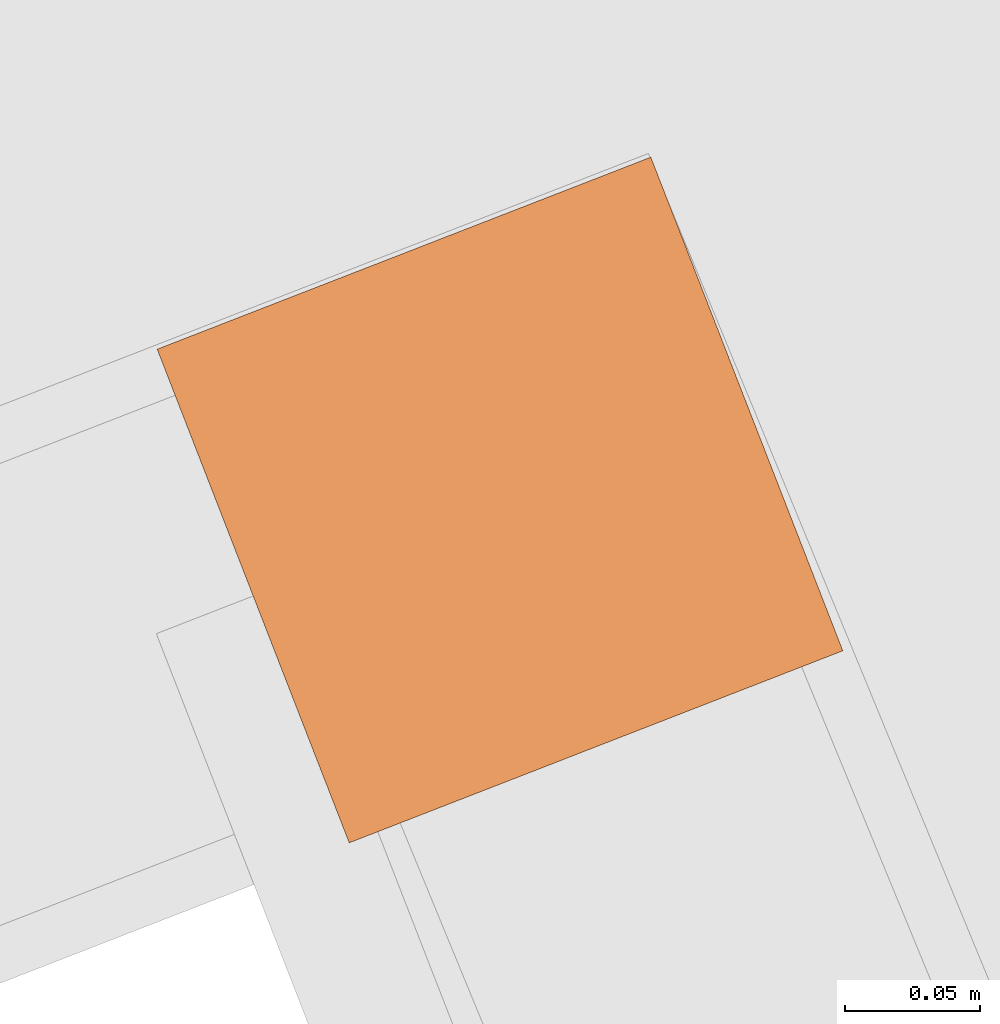
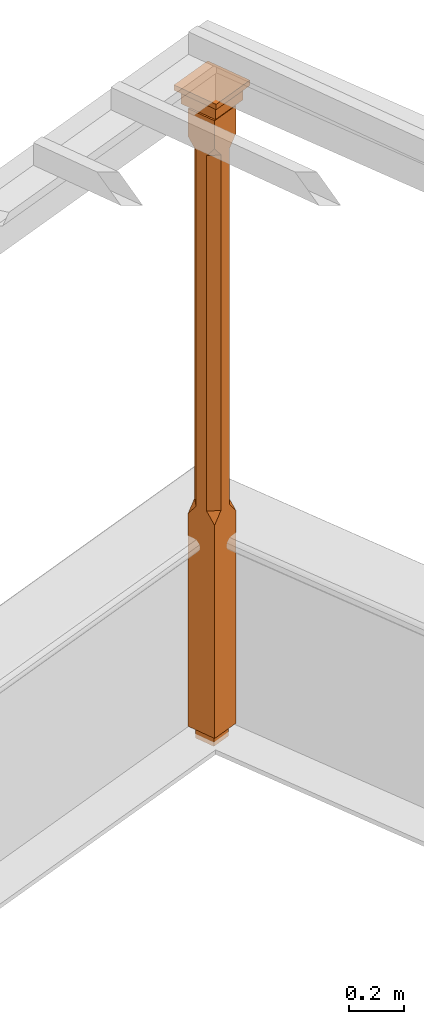
# One storey, part 11 of 11: 1 proxy.
"""IFC2X3 building model written with IfcOpenShell, lengths in metres."""

from ifc_helpers import new_model, si_unit, frame, origin, place, context, subcontext, project, spatial, faceted_brep, element, save


model = new_model("IFC2X3")

# Units and contexts
model_context = context("Model", 3, world=origin())
body_context = subcontext(model_context, "Body", "Model", "MODEL_VIEW")
ifc_project = project(units=[si_unit("PLANEANGLEUNIT", "RADIAN"), si_unit("MASSUNIT", "GRAM", prefix="KILO"), si_unit("FORCEUNIT", "NEWTON", prefix="KILO"), si_unit("LENGTHUNIT", "METRE")], contexts=[model_context])

# Site, building, storey
site_placement = place(None, origin())
site = spatial("IfcSite", under=ifc_project, at=site_placement, CompositionType="ELEMENT")
building_placement = place(None, origin())
building = spatial("IfcBuilding", under=site, at=building_placement, Name="Building plot-3", CompositionType="ELEMENT")
storey_placement = place(None, frame((0.0, 0.0, 5.45)))
storey = spatial("IfcBuildingStorey", under=building, at=storey_placement, Name="Floor 1", CompositionType="ELEMENT", Elevation=5.45)

# Proxy
proxy_placement = place(storey_placement, frame((42.3694898924601, 54.4597230253738, 0.0), z_axis=(0.0, 0.0, 1.0), x_axis=(-0.931964017594114, -0.36255078252548, 0.0)))
element("IfcBuildingElementProxy", 1, at=proxy_placement, inside=storey, Name="pergola post", CompositionType="ELEMENT", context=body_context, shape_type="Brep", held_by="IfcProductRepresentation", body=[
    faceted_brep([(0.0246, -0.0615, 2.62), (0.0615, -0.0246, 2.62), (0.0615, -0.0615, 2.666667), (0.0615, -0.0246, 1.044444), (0.0246, -0.0615, 1.044444), (0.0615, 0.0246, 2.62), (0.0615, 0.0615, 2.666667), (-0.0246, -0.0615, 2.62), (-0.0615, -0.0615, 2.666667), (-0.0246, -0.0615, 1.044444), (0.0615, -0.0615, 0.997778), (0.0615, 0.0246, 1.044444), (0.0246, 0.0615, 2.62), (0.0615, 0.0615, 2.791111), (0.0615, -0.0615, 2.791111), (-0.0615, -0.0615, 2.791111), (-0.0615, -0.0246, 2.62), (-0.0615, -0.0246, 1.044444), (-0.0615, -0.0615, 0.997778), (0.0615, 0.0615, 0.997778), (0.0246, 0.0615, 1.044444), (-0.0246, 0.0615, 2.62), (-0.0615, 0.0615, 2.666667), (0.04305, 0.04305, 2.791111), (0.04305, -0.04305, 2.791111), (-0.0615, 0.0615, 2.791111), (-0.04305, -0.04305, 2.791111), (-0.0615, 0.0246, 2.62), (-0.0615, 0.0246, 1.044444), (0.0615, -0.0615, 0.053333), (-0.0615, -0.0615, 0.053333), (0.0615, 0.0615, 0.053333), (-0.0246, 0.0615, 1.044444), (-0.04305, 0.04305, 2.791111), (0.04305, 0.04305, 2.814444), (0.04305, -0.04305, 2.814444), (-0.04305, -0.04305, 2.814444), (-0.0615, 0.0615, 0.997778), (-0.0615, 0.0615, 0.053333), (-0.04305, -0.04305, 0.053333), (0.04305, -0.04305, 0.053333), (0.04305, 0.04305, 0.053333), (-0.04305, 0.04305, 2.814444), (0.07995, 0.07995, 2.814444), (0.07995, -0.07995, 2.814444), (-0.07995, -0.07995, 2.814444), (-0.04305, 0.04305, 0.053333), (-0.04305, -0.04305, 0.0), (0.04305, -0.04305, 0.0), (0.04305, 0.04305, 0.0), (-0.07995, 0.07995, 2.814444), (0.07995, 0.07995, 2.876667), (0.07995, -0.07995, 2.876667), (-0.07995, -0.07995, 2.876667), (-0.04305, 0.04305, 0.0), (-0.07995, 0.07995, 2.876667), (0.0984, 0.0984, 2.876667), (0.0984, -0.0984, 2.876667), (-0.0984, -0.0984, 2.876667), (-0.0984, 0.0984, 2.876667), (0.0984, 0.0984, 2.9), (0.0984, -0.0984, 2.9), (-0.0984, -0.0984, 2.9), (-0.0984, 0.0984, 2.9)], [[[0, 1, 2]], [[3, 1, 0, 4]], [[1, 5, 6, 2]], [[7, 0, 2, 8]], [[4, 0, 7, 9]], [[3, 4, 10]], [[1, 3, 11, 5]], [[5, 12, 6]], [[13, 14, 2, 6]], [[15, 8, 2, 14]], [[8, 16, 7]], [[9, 7, 16, 17]], [[9, 18, 10, 4]], [[3, 10, 19, 11]], [[20, 12, 5, 11]], [[21, 22, 6, 12]], [[14, 13, 23, 24]], [[13, 6, 22, 25]], [[25, 22, 8, 15]], [[26, 15, 14, 24]], [[16, 8, 22, 27]], [[27, 28, 17, 16]], [[17, 18, 9]], [[29, 10, 18, 30]], [[31, 19, 10, 29]], [[20, 11, 19]], [[12, 20, 32, 21]], [[21, 27, 22]], [[33, 23, 13, 25]], [[23, 34, 35, 24]], [[26, 33, 25, 15]], [[36, 26, 24, 35]], [[28, 27, 21, 32]], [[17, 28, 37, 18]], [[38, 30, 18, 37]], [[29, 30, 39, 40]], [[31, 38, 37, 19]], [[40, 41, 31, 29]], [[32, 20, 19, 37]], [[33, 42, 34, 23]], [[43, 44, 35, 34]], [[42, 33, 26, 36]], [[36, 35, 44, 45]], [[28, 32, 37]], [[46, 39, 30, 38]], [[39, 47, 48, 40]], [[46, 38, 31, 41]], [[49, 41, 40, 48]], [[43, 34, 42, 50]], [[43, 51, 52, 44]], [[45, 50, 42, 36]], [[53, 45, 44, 52]], [[46, 54, 47, 39]], [[54, 46, 41, 49]], [[50, 55, 51, 43]], [[56, 57, 52, 51]], [[55, 50, 45, 53]], [[53, 52, 57, 58]], [[56, 51, 55, 59]], [[56, 60, 61, 57]], [[58, 59, 55, 53]], [[62, 58, 57, 61]], [[59, 63, 60, 56]], [[63, 62, 61, 60]], [[58, 62, 63, 59]], [[47, 54, 49, 48]]]),
])

save(model, "model.ifc")
